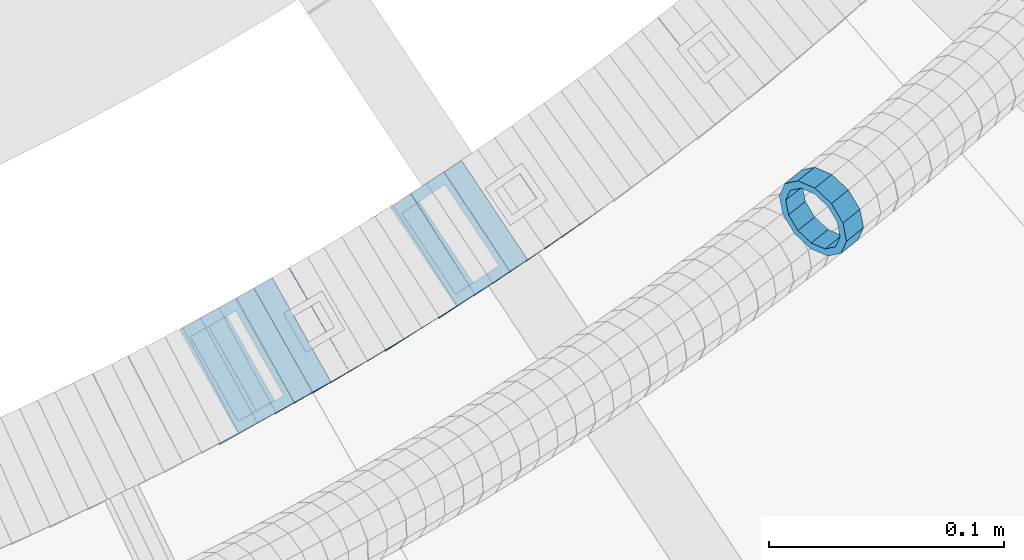
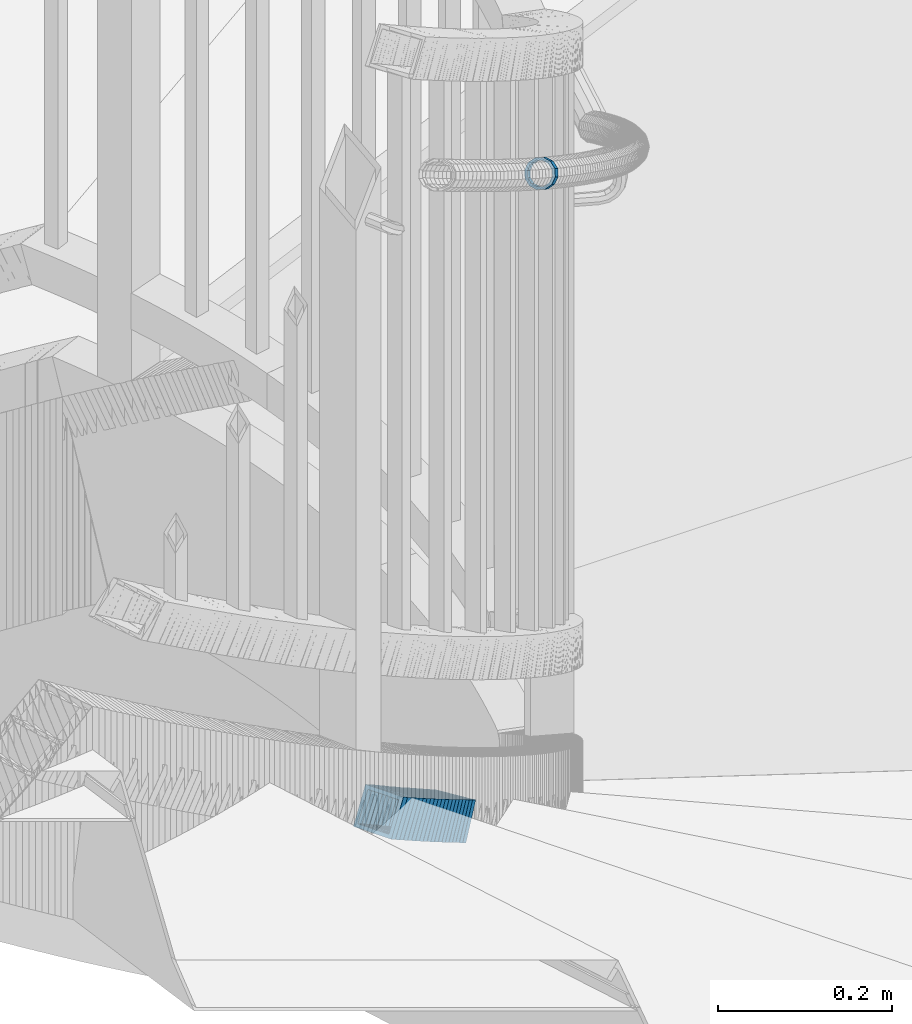
# One storey, part 736 of 975: 21 members.
"""IFC2X3 building model written with IfcOpenShell, lengths in millimetres."""

from ifc_helpers import new_model, si_unit, frame, origin_with_axes, place, context, subcontext, project, spatial, faceted_brep, material, type_object, element, save


model = new_model("IFC2X3")

# Units and contexts
model_context = context("Model", 3, precision=1e-05, world=origin_with_axes())
body_context = subcontext(model_context, "Body", "Model", "MODEL_VIEW")
ifc_project = project(units=[si_unit("LENGTHUNIT", "METRE", prefix="MILLI"), si_unit("AREAUNIT", "SQUARE_METRE"), si_unit("VOLUMEUNIT", "CUBIC_METRE"), si_unit("MASSUNIT", "GRAM", prefix="KILO"), si_unit("TIMEUNIT", "SECOND"), si_unit("PLANEANGLEUNIT", "RADIAN"), si_unit("SOLIDANGLEUNIT", "STERADIAN"), si_unit("THERMODYNAMICTEMPERATUREUNIT", "DEGREE_CELSIUS"), si_unit("LUMINOUSINTENSITYUNIT", "LUMEN")], contexts=[model_context])

# Site, building, storey
site_placement = place(None, origin_with_axes())
site = spatial("IfcSite", under=ifc_project, at=site_placement, CompositionType="ELEMENT")
building_placement = place(site_placement, origin_with_axes())
building = spatial("IfcBuilding", under=site, at=building_placement, Name="Undefined", CompositionType="ELEMENT")
storey_placement = place(building_placement, origin_with_axes())
storey = spatial("IfcBuildingStorey", under=building, at=storey_placement, Name="Undefined", CompositionType="ELEMENT", Elevation=0.0)

# Members
ifc_material = material()
member_type_1 = type_object("IfcMemberType", PredefinedType="NOTDEFINED")
member_1_placement = place(storey_placement, frame((35655.3128996887, 2245.45662166805, 3593.96255062153), z_axis=(0.627329537606273, -0.77875390929786, 3.09570168610662e-10), x_axis=(-0.659690385079403, -0.531417254063974, 0.531417254063974)))
element("IfcMember", 1, at=member_1_placement, inside=storey, type_object=member_type_1, material=ifc_material, Name="WALL", context=body_context, shape_type="Brep", body=[
    faceted_brep([(-2.1246523829177e-07, -15.367000000002, 0.0), (-1.83998054126278e-07, -13.3082123799541, 7.68350000000009), (10.9055031979988, -13.3082123799322, 7.68349999999873), (10.9055031979988, -15.3669999999729, -1.81898940354586e-12), (-1.06232619145885e-07, -7.68349999999919, 13.3082123799559), (10.9055031979842, -7.683499999981, 13.3082123799552), (-3.63797880709171e-12, 3.63797880709171e-12, 15.3670000000002), (10.9055031979697, 7.27595761418343e-12, 15.3670000000002), (1.06225343188271e-07, 7.68350000000646, 13.3082123799559), (10.9055031979478, 7.68349999999191, 13.3082123799561), (1.8399441614747e-07, 13.308212379965, 7.68350000000009), (10.9055031979333, 13.3082123799395, 7.68350000000078), (2.12461600312963e-07, 15.3670000000093, 0.0), (10.9055031979187, 15.3669999999802, 4.54747350886464e-13), (1.8399441614747e-07, 13.308212379965, -7.68350000000009), (10.9055031979187, 13.3082123799395, -7.68350000000009), (1.06225343188271e-07, 7.68350000000646, -13.3082123799559), (10.9055031979296, 7.68349999999191, -13.3082123799561), (-3.63797880709171e-12, 3.63797880709171e-12, -15.3670000000002), (10.9055031979478, 3.63797880709171e-12, -15.3670000000013), (-1.06232619145885e-07, -7.68349999999919, -13.3082123799559), (10.9055031979697, -7.683499999981, -13.3082123799575), (-1.83998054126278e-07, -13.3082123799541, -7.68350000000009), (10.9055031979842, -13.3082123799286, -7.68350000000214), (-2.63386027654633e-07, -19.0500000000029, 0.0), (-2.28097633225843e-07, -16.4977839420972, -9.52499999999964), (10.9055031979879, -16.4977839420681, -9.52500000000214), (10.9055031980097, -19.0499999999629, -2.04636307898909e-12), (-1.31691194837913e-07, -9.52500000000146, -16.4977839420935), (10.9055031979624, -9.52499999998327, -16.4977839420956), (-3.63797880709171e-12, 3.63797880709171e-12, -19.0500000000002), (10.9055031979406, 3.63797880709171e-12, -19.0500000000015), (1.31687556859106e-07, 9.52500000000509, -16.4977839420935), (10.9055031979151, 9.5249999999869, -16.4977839420942), (2.28097633225843e-07, 16.4977839421044, -9.52499999999964), (10.9055031979115, 16.4977839420717, -9.52499999999986), (2.63382389675826e-07, 19.0500000000138, 0.0), (10.9055031979115, 19.0499999999774, 6.82121026329696e-13), (2.28097633225843e-07, 16.4977839421044, 9.52499999999964), (10.9055031979296, 16.4977839420753, 9.52500000000123), (1.31687556859106e-07, 9.52500000000509, 16.4977839420935), (10.9055031979515, 9.52499999999054, 16.4977839420942), (-3.63797880709171e-12, 3.63797880709171e-12, 19.0500000000002), (10.9055031979733, 7.27595761418343e-12, 19.0500000000004), (-1.31691194837913e-07, -9.52500000000146, 16.4977839420935), (10.9055031979988, -9.52499999997599, 16.4977839420933), (-2.28097633225843e-07, -16.4977839420972, 9.52499999999964), (10.905503198006, -16.4977839420644, 9.52499999999873)], [[[0, 1, 2, 3]], [[1, 4, 5, 2]], [[4, 6, 7, 5]], [[6, 8, 9, 7]], [[8, 10, 11, 9]], [[10, 12, 13, 11]], [[12, 14, 15, 13]], [[14, 16, 17, 15]], [[16, 18, 19, 17]], [[18, 20, 21, 19]], [[20, 22, 23, 21]], [[22, 0, 3, 23]], [[24, 25, 26, 27]], [[25, 28, 29, 26]], [[28, 30, 31, 29]], [[30, 32, 33, 31]], [[32, 34, 35, 33]], [[34, 36, 37, 35]], [[36, 38, 39, 37]], [[38, 40, 41, 39]], [[40, 42, 43, 41]], [[42, 44, 45, 43]], [[44, 46, 47, 45]], [[46, 24, 27, 47]], [[29, 31, 33, 35, 37, 39, 41, 43, 45, 47, 27, 26], [5, 7, 9, 11, 13, 15, 17, 19, 21, 23, 3, 2]], [[46, 44, 42, 40, 38, 36, 34, 32, 30, 28, 25, 24], [22, 20, 18, 16, 14, 12, 10, 8, 6, 4, 1, 0]]]),
])
member_type_2 = type_object("IfcMemberType", Name="HSS2X2X.188_TUBES", PredefinedType="NOTDEFINED")
member_2_placement = place(storey_placement, frame((35403.1596586216, 2176.81287776112, 2829.18067466217), z_axis=(0.491321186669782, -0.870978467890795, 1.51524091052124e-10), x_axis=(-0.731050131101344, -0.412387253057188, 0.543601379075379)))
element("IfcMember", 2, at=member_2_placement, inside=storey, type_object=member_type_2, material=ifc_material, Name="WALL", ObjectType="HSS2X2X.188_TUBES", context=body_context, shape_type="Brep", body=[
    faceted_brep([(0.0, 20.6374999999753, -20.6375000000298), (0.0, -20.6375000000153, -20.6375000000153), (10.6709887076922, -20.6374999999844, -20.6374999999825), (10.6709887076995, 20.6375000000171, -20.6374999999753), (0.0, -20.6374999999825, 20.6375000000335), (10.6709887076922, -20.6374999999971, 20.6375000000153), (0.0, 20.6375000000116, 20.6375000000189), (10.6709887076941, 20.6375000000025, 20.6375000000189), (0.0, 25.3999999999724, -25.4000000000342), (0.0, 25.400000000016, 25.4000000000196), (10.6709887076959, 25.3999999999996, 25.4000000000233), (10.6709887077013, 25.4000000000178, -25.3999999999724), (0.0, -25.399999999976, 25.4000000000378), (10.6709887076904, -25.3999999999978, 25.400000000016), (0.0, -25.400000000016, -25.4000000000196), (10.6709887076959, -25.3999999999796, -25.3999999999796)], [[[0, 1, 2, 3]], [[1, 4, 5, 2]], [[4, 6, 7, 5]], [[6, 0, 3, 7]], [[8, 9, 10, 11]], [[9, 12, 13, 10]], [[12, 14, 15, 13]], [[14, 8, 11, 15]], [[13, 15, 11, 10], [5, 7, 3, 2]], [[14, 12, 9, 8], [6, 4, 1, 0]]]),
])
for number, where, z_axis, x_axis, name in (
    (3, (35411.1068520738, 2181.29590996488, 2823.37216906364), (0.491321186669782, -0.870978467890795, 1.51524091052124e-10), (-0.734770841274876, -0.414486115155066, 0.536947922200908), "WALL"),
    (4, (35418.9068520737, 2185.69590996487, 2817.67216906365), (0.491321186669782, -0.870978467890795, 1.51524091052124e-10), (-0.734770841274876, -0.414486115155066, 0.536947922200908), "WALL"),
):
    element("IfcMember", number, at=place(storey_placement, frame(where, z_axis=z_axis, x_axis=x_axis)), inside=storey, type_object=member_type_2, material=ifc_material, Name=name, ObjectType="HSS2X2X.188_TUBES", context=body_context, shape_type="Brep", body=[
        faceted_brep([(0.0, 20.6374999999753, -20.6375000000298), (0.0, -20.6375000000153, -20.6375000000153), (10.6216759506497, -20.637499999968, -20.6374999999534), (10.6216759506497, 20.6375000000262, -20.6374999999643), (0.0, -20.6374999999825, 20.6375000000335), (10.6216759506169, -20.6374999999935, 20.637500000008), (0.0, 20.6375000000116, 20.6375000000189), (10.6216759506242, 20.6375000000007, 20.6374999999971), (0.0, 25.3999999999724, -25.4000000000342), (0.0, 25.400000000016, 25.4000000000196), (10.6216759506169, 25.3999999999978, 25.3999999999869), (10.6216759506533, 25.4000000000269, -25.3999999999614), (0.0, -25.399999999976, 25.4000000000378), (10.6216759506242, -25.3999999999942, 25.4000000000051), (0.0, -25.400000000016, -25.4000000000196), (10.6216759506569, -25.3999999999614, -25.3999999999432)], [[[0, 1, 2, 3]], [[1, 4, 5, 2]], [[4, 6, 7, 5]], [[6, 0, 3, 7]], [[8, 9, 10, 11]], [[9, 12, 13, 10]], [[12, 14, 15, 13]], [[14, 8, 11, 15]], [[13, 15, 11, 10], [5, 7, 3, 2]], [[14, 12, 9, 8], [6, 4, 1, 0]]]),
    ])
member_3_placement = place(storey_placement, frame((35426.4589226349, 2189.90195285872, 2811.94601811882), z_axis=(0.499722453606395, -0.866185585981205, -3.44356067216722e-10), x_axis=(-0.728209106903342, -0.420120638944253, 0.541488822928147)))
element("IfcMember", 5, at=member_3_placement, inside=storey, type_object=member_type_2, material=ifc_material, Name="WALL", ObjectType="HSS2X2X.188_TUBES", context=body_context, shape_type="Brep", body=[
    faceted_brep([(0.0, 20.6374999999753, -20.6375000000298), (0.0, -20.6375000000153, -20.6375000000153), (10.7093417165161, -20.637499999968, -20.6374999999534), (10.709341716436, 20.6374999999898, -20.6375000000116), (0.0, -20.6374999999825, 20.6375000000335), (10.7093417164688, -20.6374999999971, 20.6375000000153), (0.0, 20.6375000000116, 20.6375000000189), (10.7093417163924, 20.6374999999643, 20.6374999999571), (0.0, 25.3999999999724, -25.4000000000342), (0.0, 25.400000000016, 25.4000000000196), (10.7093417163815, 25.3999999999542, 25.3999999999469), (10.7093417164288, 25.3999999999869, -25.4000000000196), (0.0, -25.399999999976, 25.4000000000378), (10.7093417164724, -25.3999999999942, 25.4000000000196), (0.0, -25.400000000016, -25.4000000000196), (10.709341716527, -25.3999999999578, -25.3999999999432)], [[[0, 1, 2, 3]], [[1, 4, 5, 2]], [[4, 6, 7, 5]], [[6, 0, 3, 7]], [[8, 9, 10, 11]], [[9, 12, 13, 10]], [[12, 14, 15, 13]], [[14, 8, 11, 15]], [[13, 15, 11, 10], [5, 7, 3, 2]], [[14, 12, 9, 8], [6, 4, 1, 0]]]),
])
member_4_placement = place(storey_placement, frame((35434.1394897285, 2194.30179687593, 2806.19775448158), z_axis=(0.504568019426507, -0.863371944049615, -2.19346475205384e-10), x_axis=(-0.727484185892216, -0.425153095937027, 0.538527254920214)))
element("IfcMember", 6, at=member_4_placement, inside=storey, type_object=member_type_2, material=ifc_material, Name="WALL", ObjectType="HSS2X2X.188_TUBES", context=body_context, shape_type="Brep", body=[
    faceted_brep([(0.0, 20.6374999999753, -20.6375000000298), (0.0, -20.6375000000153, -20.6375000000153), (10.5806427026419, -20.6374999999607, -20.6374999999316), (10.5806427026473, 20.6375000000444, -20.6374999999207), (0.0, -20.6374999999825, 20.6375000000335), (10.5806427025509, -20.6375000000207, 20.6374999999643), (0.0, 20.6375000000116, 20.6375000000189), (10.5806427025545, 20.6374999999862, 20.6374999999716), (0.0, 25.3999999999724, -25.4000000000342), (0.0, 25.400000000016, 25.4000000000196), (10.5806427025436, 25.3999999999796, 25.3999999999614), (10.5806427026582, 25.4000000000542, -25.3999999999105), (0.0, -25.399999999976, 25.4000000000378), (10.5806427025418, -25.4000000000287, 25.3999999999542), (0.0, -25.400000000016, -25.4000000000196), (10.5806427026528, -25.3999999999542, -25.3999999999178)], [[[0, 1, 2, 3]], [[1, 4, 5, 2]], [[4, 6, 7, 5]], [[6, 0, 3, 7]], [[8, 9, 10, 11]], [[9, 12, 13, 10]], [[12, 14, 15, 13]], [[14, 8, 11, 15]], [[13, 15, 11, 10], [5, 7, 3, 2]], [[14, 12, 9, 8], [6, 4, 1, 0]]]),
])
member_5_placement = place(storey_placement, frame((35441.598327349, 2198.60572369306, 2800.47087936196), z_axis=(0.51285525212439, -0.858475095951204, -8.52323864819481e-11), x_axis=(-0.720886570579887, -0.43065950974905, 0.543005468683582)))
element("IfcMember", 7, at=member_5_placement, inside=storey, type_object=member_type_2, material=ifc_material, Name="WALL", ObjectType="HSS2X2X.188_TUBES", context=body_context, shape_type="Brep", body=[
    faceted_brep([(0.0, 20.6374999999753, -20.6375000000298), (0.0, -20.6375000000153, -20.6375000000153), (10.6831643251735, -20.6375000000498, -20.6375000000953), (10.6831643252044, 20.637499999988, -20.6375000000226), (0.0, -20.6374999999825, 20.6375000000335), (10.6831643251935, -20.6375000000135, 20.637499999968), (0.0, 20.6375000000116, 20.6375000000189), (10.6831643252244, 20.6375000000226, 20.6375000000407), (0.0, 25.3999999999724, -25.4000000000342), (0.0, 25.400000000016, 25.4000000000196), (10.6831643252317, 25.4000000000306, 25.4000000000597), (10.6831643252044, 25.3999999999905, -25.4000000000196), (0.0, -25.399999999976, 25.4000000000378), (10.6831643251917, -25.400000000016, 25.3999999999614), (0.0, -25.400000000016, -25.4000000000196), (10.6831643251644, -25.400000000056, -25.4000000001179)], [[[0, 1, 2, 3]], [[1, 4, 5, 2]], [[4, 6, 7, 5]], [[6, 0, 3, 7]], [[8, 9, 10, 11]], [[9, 12, 13, 10]], [[12, 14, 15, 13]], [[14, 8, 11, 15]], [[13, 15, 11, 10], [5, 7, 3, 2]], [[14, 12, 9, 8], [6, 4, 1, 0]]]),
])
member_6_placement = place(storey_placement, frame((35449.1784894769, 2203.1011392955, 2794.72209377705), z_axis=(0.517802678981105, -0.855500079275268, 1.01825207821094e-10), x_axis=(-0.720031514804977, -0.435808547881956, 0.540023635853721)))
element("IfcMember", 8, at=member_6_placement, inside=storey, type_object=member_type_2, material=ifc_material, Name="WALL", ObjectType="HSS2X2X.188_TUBES", context=body_context, shape_type="Brep", body=[
    faceted_brep([(0.0, 20.6374999999753, -20.6375000000298), (0.0, -20.6375000000153, -20.6375000000153), (10.5550935571373, -20.6374999999935, -20.6374999999753), (10.5550935571373, 20.6375000000025, -20.6374999999862), (0.0, -20.6374999999825, 20.6375000000335), (10.5550935571027, -20.6374999999989, 20.6374999999862), (0.0, 20.6375000000116, 20.6375000000189), (10.5550935571027, 20.6374999999953, 20.6374999999716), (0.0, 25.3999999999724, -25.4000000000342), (0.0, 25.400000000016, 25.4000000000196), (10.5550935570991, 25.3999999999924, 25.3999999999651), (10.5550935571373, 25.3999999999996, -25.3999999999905), (0.0, -25.399999999976, 25.4000000000378), (10.5550935571009, -25.3999999999996, 25.3999999999833), (0.0, -25.400000000016, -25.4000000000196), (10.5550935571428, -25.3999999999905, -25.3999999999724)], [[[0, 1, 2, 3]], [[1, 4, 5, 2]], [[4, 6, 7, 5]], [[6, 0, 3, 7]], [[8, 9, 10, 11]], [[9, 12, 13, 10]], [[12, 14, 15, 13]], [[14, 8, 11, 15]], [[13, 15, 11, 10], [5, 7, 3, 2]], [[14, 12, 9, 8], [6, 4, 1, 0]]]),
])
member_7_placement = place(storey_placement, frame((35456.8069512311, 2207.69752496903, 2788.9348533772), z_axis=(0.521001549994652, -0.853555730402632, -1.97164808923844e-10), x_axis=(-0.717966273129313, -0.438239154078941, 0.540805764097407)))
element("IfcMember", 9, at=member_7_placement, inside=storey, type_object=member_type_2, material=ifc_material, Name="WALL", ObjectType="HSS2X2X.188_TUBES", context=body_context, shape_type="Brep", body=[
    faceted_brep([(0.0, 20.6374999999753, -20.6375000000298), (0.0, -20.6375000000153, -20.6375000000153), (10.7247377590011, -20.6375000000189, -20.6375000000589), (10.7247377589938, 20.6374999999844, -20.6375000000698), (0.0, -20.6374999999825, 20.6375000000335), (10.7247377590484, -20.6374999999771, 20.6375000000517), (0.0, 20.6375000000116, 20.6375000000189), (10.7247377590447, 20.6375000000262, 20.6375000000407), (0.0, 25.3999999999724, -25.4000000000342), (0.0, 25.400000000016, 25.4000000000196), (10.7247377590484, 25.4000000000342, 25.400000000056), (10.7247377589902, 25.3999999999778, -25.4000000000851), (0.0, -25.399999999976, 25.4000000000378), (10.7247377590556, -25.3999999999724, 25.4000000000633), (0.0, -25.400000000016, -25.4000000000196), (10.7247377589938, -25.4000000000251, -25.4000000000742)], [[[0, 1, 2, 3]], [[1, 4, 5, 2]], [[4, 6, 7, 5]], [[6, 0, 3, 7]], [[8, 9, 10, 11]], [[9, 12, 13, 10]], [[12, 14, 15, 13]], [[14, 8, 11, 15]], [[13, 15, 11, 10], [5, 7, 3, 2]], [[14, 12, 9, 8], [6, 4, 1, 0]]]),
])
member_8_placement = place(storey_placement, frame((35464.3879811797, 2212.29213373258, 2783.18569583919), z_axis=(0.525969302181787, -0.850503552704164, -1.9787603378063e-10), x_axis=(-0.71704495166101, -0.443435693790348, 0.537783713745715)))
element("IfcMember", 10, at=member_8_placement, inside=storey, type_object=member_type_2, material=ifc_material, Name="WALL", ObjectType="HSS2X2X.188_TUBES", context=body_context, shape_type="Brep", body=[
    faceted_brep([(0.0, 20.6374999999753, -20.6375000000298), (0.0, -20.6375000000153, -20.6375000000153), (10.6004716875832, -20.6375000000153, -20.6375000000553), (10.6004716875814, 20.6374999999898, -20.6375000000444), (0.0, -20.6374999999825, 20.6375000000335), (10.6004716876068, -20.6375000000044, 20.6374999999862), (0.0, 20.6375000000116, 20.6375000000189), (10.6004716876032, 20.6374999999989, 20.6374999999971), (0.0, 25.3999999999724, -25.4000000000342), (0.0, 25.400000000016, 25.4000000000196), (10.600471687605, 25.4000000000015, 25.4000000000051), (10.6004716875814, 25.3999999999869, -25.4000000000487), (0.0, -25.399999999976, 25.4000000000378), (10.6004716876068, -25.4000000000015, 25.3999999999905), (0.0, -25.400000000016, -25.4000000000196), (10.6004716875814, -25.4000000000178, -25.4000000000669)], [[[0, 1, 2, 3]], [[1, 4, 5, 2]], [[4, 6, 7, 5]], [[6, 0, 3, 7]], [[8, 9, 10, 11]], [[9, 12, 13, 10]], [[12, 14, 15, 13]], [[14, 8, 11, 15]], [[13, 15, 11, 10], [5, 7, 3, 2]], [[14, 12, 9, 8], [6, 4, 1, 0]]]),
])
member_9_placement = place(storey_placement, frame((35471.6393027925, 2216.68588661606, 2777.50753289956), z_axis=(0.539053696363117, -0.842271400700072, -2.99270595860435e-10), x_axis=(-0.709380442229691, -0.454003483147033, 0.5391291361746)))
element("IfcMember", 11, at=member_9_placement, inside=storey, type_object=member_type_2, material=ifc_material, Name="WALL", ObjectType="HSS2X2X.188_TUBES", context=body_context, shape_type="Brep", body=[
    faceted_brep([(0.0, 20.6374999999753, -20.6375000000298), (0.0, -20.6375000000153, -20.6375000000153), (10.5744976239494, -20.6375000000207, -20.6375000000335), (10.5744976239657, 20.6375000000098, -20.637500000008), (0.0, -20.6374999999825, 20.6375000000335), (10.5744976239639, -20.6375000000244, 20.6374999999753), (0.0, 20.6375000000116, 20.6375000000189), (10.5744976239803, 20.6374999999989, 20.6374999999935), (0.0, 25.3999999999724, -25.4000000000342), (0.0, 25.400000000016, 25.4000000000196), (10.5744976239857, 25.4000000000051, 25.4000000000015), (10.5744976239675, 25.4000000000124, -25.4000000000051), (0.0, -25.399999999976, 25.4000000000378), (10.5744976239639, -25.4000000000287, 25.3999999999724), (0.0, -25.400000000016, -25.4000000000196), (10.5744976239494, -25.4000000000215, -25.4000000000378)], [[[0, 1, 2, 3]], [[1, 4, 5, 2]], [[4, 6, 7, 5]], [[6, 0, 3, 7]], [[8, 9, 10, 11]], [[9, 12, 13, 10]], [[12, 14, 15, 13]], [[14, 8, 11, 15]], [[13, 15, 11, 10], [5, 7, 3, 2]], [[14, 12, 9, 8], [6, 4, 1, 0]]]),
])
member_10_placement = place(storey_placement, frame((35479.2583846463, 2221.59560662445, 2771.75724533005), z_axis=(0.533992991595071, -0.845488902900178, -3.59032583219232e-10), x_axis=(-0.710435520923845, -0.448696118951872, 0.542174476941872)))
element("IfcMember", 12, at=member_10_placement, inside=storey, type_object=member_type_2, material=ifc_material, Name="WALL", ObjectType="HSS2X2X.188_TUBES", context=body_context, shape_type="Brep", body=[
    faceted_brep([(0.0, 20.6374999999753, -20.6375000000298), (0.0, -20.6375000000153, -20.6375000000153), (10.6985980389491, -20.6375000000317, -20.6375000000698), (10.6985980389982, 20.6375000000116, -20.6374999999643), (0.0, -20.6374999999825, 20.6375000000335), (10.6985980389818, -20.6374999999989, 20.6374999999789), (0.0, 20.6375000000116, 20.6375000000189), (10.6985980390309, 20.6375000000407, 20.6375000000808), (0.0, 25.3999999999724, -25.4000000000342), (0.0, 25.400000000016, 25.4000000000196), (10.6985980390382, 25.4000000000487, 25.4000000000997), (10.6985980390036, 25.4000000000142, -25.3999999999542), (0.0, -25.399999999976, 25.4000000000378), (10.6985980389763, -25.4000000000033, 25.3999999999724), (0.0, -25.400000000016, -25.4000000000196), (10.6985980389418, -25.400000000036, -25.4000000000851)], [[[0, 1, 2, 3]], [[1, 4, 5, 2]], [[4, 6, 7, 5]], [[6, 0, 3, 7]], [[8, 9, 10, 11]], [[9, 12, 13, 10]], [[12, 14, 15, 13]], [[14, 8, 11, 15]], [[13, 15, 11, 10], [5, 7, 3, 2]], [[14, 12, 9, 8], [6, 4, 1, 0]]]),
])
member_11_placement = place(storey_placement, frame((35486.7393027925, 2226.28588661606, 2766.00753289956), z_axis=(0.539053696363117, -0.842271400700072, -2.99270595860435e-10), x_axis=(-0.709380442229691, -0.454003483147033, 0.5391291361746)))
element("IfcMember", 13, at=member_11_placement, inside=storey, type_object=member_type_2, material=ifc_material, Name="WALL", ObjectType="HSS2X2X.188_TUBES", context=body_context, shape_type="Brep", body=[
    faceted_brep([(0.0, 20.6374999999753, -20.6375000000298), (0.0, -20.6375000000153, -20.6375000000153), (10.5744976239494, -20.6375000000207, -20.6375000000335), (10.5744976239657, 20.6375000000098, -20.637500000008), (0.0, -20.6374999999825, 20.6375000000335), (10.5744976239639, -20.6375000000244, 20.6374999999753), (0.0, 20.6375000000116, 20.6375000000189), (10.5744976239803, 20.6374999999989, 20.6374999999935), (0.0, 25.3999999999724, -25.4000000000342), (0.0, 25.400000000016, 25.4000000000196), (10.5744976239857, 25.4000000000051, 25.4000000000015), (10.5744976239675, 25.4000000000124, -25.4000000000051), (0.0, -25.399999999976, 25.4000000000378), (10.5744976239639, -25.4000000000287, 25.3999999999724), (0.0, -25.400000000016, -25.4000000000196), (10.5744976239494, -25.4000000000215, -25.4000000000378)], [[[0, 1, 2, 3]], [[1, 4, 5, 2]], [[4, 6, 7, 5]], [[6, 0, 3, 7]], [[8, 9, 10, 11]], [[9, 12, 13, 10]], [[12, 14, 15, 13]], [[14, 8, 11, 15]], [[13, 15, 11, 10], [5, 7, 3, 2]], [[14, 12, 9, 8], [6, 4, 1, 0]]]),
])
member_12_placement = place(storey_placement, frame((35493.8976285115, 2230.77393133963, 2760.328027268), z_axis=(0.552097343096909, -0.833779661388627, 8.59072315506636e-11), x_axis=(-0.701555755945148, -0.464543675963691, 0.540387540957759)))
element("IfcMember", 14, at=member_12_placement, inside=storey, type_object=member_type_2, material=ifc_material, Name="WALL", ObjectType="HSS2X2X.188_TUBES", context=body_context, shape_type="Brep", body=[
    faceted_brep([(0.0, 20.6374999999753, -20.6375000000298), (0.0, -20.6375000000153, -20.6375000000153), (10.5531985672587, -20.6374999999916, -20.6375000000007), (10.5531985672878, 20.6375000000062, -20.6374999999789), (0.0, -20.6374999999825, 20.6375000000335), (10.5531985672114, -20.6375000000353, 20.6374999999171), (0.0, 20.6375000000116, 20.6375000000189), (10.5531985672333, 20.6374999999607, 20.6374999999316), (0.0, 25.3999999999724, -25.4000000000342), (0.0, 25.400000000016, 25.4000000000196), (10.5531985672314, 25.399999999956, 25.3999999999251), (10.5531985672933, 25.4000000000106, -25.3999999999724), (0.0, -25.399999999976, 25.4000000000378), (10.5531985672023, -25.4000000000397, 25.3999999999069), (0.0, -25.400000000016, -25.4000000000196), (10.5531985672642, -25.3999999999851, -25.3999999999869)], [[[0, 1, 2, 3]], [[1, 4, 5, 2]], [[4, 6, 7, 5]], [[6, 0, 3, 7]], [[8, 9, 10, 11]], [[9, 12, 13, 10]], [[12, 14, 15, 13]], [[14, 8, 11, 15]], [[13, 15, 11, 10], [5, 7, 3, 2]], [[14, 12, 9, 8], [6, 4, 1, 0]]]),
])
member_13_placement = place(storey_placement, frame((35501.480447215, 2235.77774183277, 2754.53213827413), z_axis=(0.554700196030179, -0.832050294467877, 1.48236722452566e-10), x_axis=(-0.703241758862587, -0.468827838908382, 0.534463736895546)))
element("IfcMember", 15, at=member_13_placement, inside=storey, type_object=member_type_2, material=ifc_material, Name="WALL", ObjectType="HSS2X2X.188_TUBES", context=body_context, shape_type="Brep", body=[
    faceted_brep([(0.0, 20.6374999999753, -20.6375000000298), (0.0, -20.6375000000153, -20.6375000000153), (10.6625512894789, -20.6374999999625, -20.6374999999389), (10.6625512893879, 20.6374999999789, -20.6375000000371), (0.0, -20.6374999999825, 20.6375000000335), (10.6625512894352, -20.6374999999989, 20.6375000000153), (0.0, 20.6375000000116, 20.6375000000189), (10.6625512893443, 20.6374999999443, 20.6374999999134), (0.0, 25.3999999999724, -25.4000000000342), (0.0, 25.400000000016, 25.4000000000196), (10.6625512893297, 25.3999999999342, 25.3999999998996), (10.6625512893916, 25.399999999976, -25.4000000000415), (0.0, -25.399999999976, 25.4000000000378), (10.6625512894389, -25.399999999996, 25.400000000016), (0.0, -25.400000000016, -25.4000000000196), (10.6625512894971, -25.3999999999523, -25.3999999999214)], [[[0, 1, 2, 3]], [[1, 4, 5, 2]], [[4, 6, 7, 5]], [[6, 0, 3, 7]], [[8, 9, 10, 11]], [[9, 12, 13, 10]], [[12, 14, 15, 13]], [[14, 8, 11, 15]], [[13, 15, 11, 10], [5, 7, 3, 2]], [[14, 12, 9, 8], [6, 4, 1, 0]]]),
])
member_14_placement = place(storey_placement, frame((35508.5819565581, 2240.47488990358, 2748.89803033737), z_axis=(0.559857411630225, -0.828588968453421, -5.37864252692088e-10), x_axis=(-0.694904609116096, -0.469530142078484, 0.544654964090997)))
element("IfcMember", 16, at=member_14_placement, inside=storey, type_object=member_type_2, material=ifc_material, Name="WALL", ObjectType="HSS2X2X.188_TUBES", context=body_context, shape_type="Brep", body=[
    faceted_brep([(0.0, 20.6374999999753, -20.6375000000298), (0.0, -20.6375000000153, -20.6375000000153), (10.648004507897, -20.6374999999862, -20.637499999968), (10.6480045078188, 20.6374999999771, -20.6375000000808), (0.0, -20.6374999999825, 20.6375000000335), (10.6480045079406, -20.6374999999698, 20.6375000001062), (0.0, 20.6375000000116, 20.6375000000189), (10.6480045078679, 20.6374999999935, 20.6375000000007), (0.0, 25.3999999999724, -25.4000000000342), (0.0, 25.400000000016, 25.4000000000196), (10.6480045078661, 25.3999999999905, 25.4000000000015), (10.648004507806, 25.3999999999705, -25.4000000000997), (0.0, -25.399999999976, 25.4000000000378), (10.6480045079552, -25.3999999999633, 25.4000000001288), (0.0, -25.400000000016, -25.4000000000196), (10.6480045078988, -25.3999999999814, -25.3999999999651)], [[[0, 1, 2, 3]], [[1, 4, 5, 2]], [[4, 6, 7, 5]], [[6, 0, 3, 7]], [[8, 9, 10, 11]], [[9, 12, 13, 10]], [[12, 14, 15, 13]], [[14, 8, 11, 15]], [[13, 15, 11, 10], [5, 7, 3, 2]], [[14, 12, 9, 8], [6, 4, 1, 0]]]),
])
member_15_placement = place(storey_placement, frame((35515.863230544, 2245.35658153436, 2743.14713360921), z_axis=(0.565089006166999, -0.825029948007461, -8.60381987877188e-11), x_axis=(-0.693573002028166, -0.475050002019327, 0.541557002022017)))
element("IfcMember", 17, at=member_15_placement, inside=storey, type_object=member_type_2, material=ifc_material, Name="WALL", ObjectType="HSS2X2X.188_TUBES", context=body_context, shape_type="Brep", body=[
    faceted_brep([(0.0, 20.6374999999753, -20.6375000000298), (0.0, -20.6375000000153, -20.6375000000153), (10.5290075505945, -20.637499999968, -20.6375000000116), (10.5290075505436, 20.6374999999898, -20.637499999998), (0.0, -20.6374999999825, 20.6375000000335), (10.5290075505145, -20.6375000000189, 20.637500000008), (0.0, 20.6375000000116, 20.6375000000189), (10.5290075504672, 20.6374999999462, 20.6375000000198), (0.0, 25.3999999999724, -25.4000000000342), (0.0, 25.400000000016, 25.4000000000196), (10.5290075504563, 25.399999999936, 25.4000000000224), (10.5290075505472, 25.3999999999869, -25.3999999999987), (0.0, -25.399999999976, 25.4000000000378), (10.5290075505072, -25.4000000000196, 25.4000000000106), (0.0, -25.400000000016, -25.4000000000196), (10.5290075506091, -25.3999999999651, -25.4000000000151)], [[[0, 1, 2, 3]], [[1, 4, 5, 2]], [[4, 6, 7, 5]], [[6, 0, 3, 7]], [[8, 9, 10, 11]], [[9, 12, 13, 10]], [[12, 14, 15, 13]], [[14, 8, 11, 15]], [[13, 15, 11, 10], [5, 7, 3, 2]], [[14, 12, 9, 8], [6, 4, 1, 0]]]),
])
member_16_placement = place(storey_placement, frame((35523.3498979407, 2250.46812147387, 2737.35033670451), z_axis=(0.567472910754157, -0.823392066733828, 3.25858309224714e-11), x_axis=(-0.695333960268593, -0.479216648185092, 0.535595078206887)))
element("IfcMember", 18, at=member_16_placement, inside=storey, type_object=member_type_2, material=ifc_material, Name="WALL", ObjectType="HSS2X2X.188_TUBES", context=body_context, shape_type="Brep", body=[
    faceted_brep([(0.0, 20.6374999999753, -20.6375000000298), (0.0, -20.6375000000153, -20.6375000000153), (10.6395488625676, -20.6374999999771, -20.6374999999716), (10.6395488625531, 20.6374999999916, -20.6375000000189), (0.0, -20.6374999999825, 20.6375000000335), (10.6395488625731, -20.6374999999844, 20.6375000000153), (0.0, 20.6375000000116, 20.6375000000189), (10.6395488625585, 20.6374999999825, 20.637499999968), (0.0, 25.3999999999724, -25.4000000000342), (0.0, 25.400000000016, 25.4000000000196), (10.6395488625567, 25.3999999999778, 25.3999999999614), (10.6395488625494, 25.3999999999887, -25.4000000000233), (0.0, -25.399999999976, 25.4000000000378), (10.6395488625749, -25.3999999999851, 25.400000000016), (0.0, -25.400000000016, -25.4000000000196), (10.6395488625658, -25.399999999976, -25.3999999999687)], [[[0, 1, 2, 3]], [[1, 4, 5, 2]], [[4, 6, 7, 5]], [[6, 0, 3, 7]], [[8, 9, 10, 11]], [[9, 12, 13, 10]], [[12, 14, 15, 13]], [[14, 8, 11, 15]], [[13, 15, 11, 10], [5, 7, 3, 2]], [[14, 12, 9, 8], [6, 4, 1, 0]]]),
])
member_17_placement = place(storey_placement, frame((35530.354622704, 2255.25670945389, 2731.71633481282), z_axis=(0.572708439164023, -0.819759137619282, -2.29586476052645e-10), x_axis=(-0.686908622877599, -0.479895065914522, 0.54576301590278)))
element("IfcMember", 19, at=member_17_placement, inside=storey, type_object=member_type_2, material=ifc_material, Name="WALL", ObjectType="HSS2X2X.188_TUBES", context=body_context, shape_type="Brep", body=[
    faceted_brep([(0.0, 20.6374999999753, -20.6375000000298), (0.0, -20.6375000000153, -20.6375000000153), (10.6348483769107, -20.637499999988, -20.6374999999825), (10.6348483768415, 20.6374999999734, -20.6375000001026), (0.0, -20.6374999999825, 20.6375000000335), (10.6348483769852, -20.6374999999589, 20.6375000001462), (0.0, 20.6375000000116, 20.6375000000189), (10.6348483769161, 20.6375000000044, 20.6375000000226), (0.0, 25.3999999999724, -25.4000000000342), (0.0, 25.400000000016, 25.4000000000196), (10.6348483769179, 25.4000000000015, 25.4000000000233), (10.6348483768288, 25.3999999999669, -25.4000000001324), (0.0, -25.399999999976, 25.4000000000378), (10.6348483769998, -25.3999999999505, 25.4000000001688), (0.0, -25.400000000016, -25.4000000000196), (10.6348483769107, -25.3999999999887, -25.3999999999833)], [[[0, 1, 2, 3]], [[1, 4, 5, 2]], [[4, 6, 7, 5]], [[6, 0, 3, 7]], [[8, 9, 10, 11]], [[9, 12, 13, 10]], [[12, 14, 15, 13]], [[14, 8, 11, 15]], [[13, 15, 11, 10], [5, 7, 3, 2]], [[14, 12, 9, 8], [6, 4, 1, 0]]]),
])
member_18_placement = place(storey_placement, frame((35537.7266443286, 2260.35364829386, 2725.86716837123), z_axis=(0.580182279890535, -0.814486661708478, -5.08648554387038e-11), x_axis=(-0.687273838311968, -0.489564926222173, 0.536638476243563)))
element("IfcMember", 20, at=member_18_placement, inside=storey, type_object=member_type_2, material=ifc_material, Name="WALL", ObjectType="HSS2X2X.188_TUBES", context=body_context, shape_type="Brep", body=[
    faceted_brep([(0.0, 20.6374999999753, -20.6375000000298), (0.0, -20.6375000000153, -20.6375000000153), (10.6216759506497, -20.637499999968, -20.6374999999534), (10.6216759506497, 20.6375000000262, -20.6374999999643), (0.0, -20.6374999999825, 20.6375000000335), (10.6216759506169, -20.6374999999935, 20.637500000008), (0.0, 20.6375000000116, 20.6375000000189), (10.6216759506242, 20.6375000000007, 20.6374999999971), (0.0, 25.3999999999724, -25.4000000000342), (0.0, 25.400000000016, 25.4000000000196), (10.6216759506169, 25.3999999999978, 25.3999999999869), (10.6216759506533, 25.4000000000269, -25.3999999999614), (0.0, -25.399999999976, 25.4000000000378), (10.6216759506242, -25.3999999999942, 25.4000000000051), (0.0, -25.400000000016, -25.4000000000196), (10.6216759506569, -25.3999999999614, -25.3999999999432)], [[[0, 1, 2, 3]], [[1, 4, 5, 2]], [[4, 6, 7, 5]], [[6, 0, 3, 7]], [[8, 9, 10, 11]], [[9, 12, 13, 10]], [[12, 14, 15, 13]], [[14, 8, 11, 15]], [[13, 15, 11, 10], [5, 7, 3, 2]], [[14, 12, 9, 8], [6, 4, 1, 0]]]),
])
member_19_placement = place(storey_placement, frame((35544.7720104363, 2265.33280008808, 2720.22367431757), z_axis=(0.58549055389883, -0.81067922836054, 1.88117155630607e-10), x_axis=(-0.682257607152531, -0.492741605110134, 0.540120605120738)))
element("IfcMember", 21, at=member_19_placement, inside=storey, type_object=member_type_2, material=ifc_material, Name="WALL", ObjectType="HSS2X2X.188_TUBES", context=body_context, shape_type="Brep", body=[
    faceted_brep([(0.0, 20.6374999999753, -20.6375000000298), (0.0, -20.6375000000153, -20.6375000000153), (10.5531985672587, -20.6374999999916, -20.6375000000007), (10.5531985672878, 20.6375000000062, -20.6374999999789), (0.0, -20.6374999999825, 20.6375000000335), (10.5531985672114, -20.6375000000353, 20.6374999999171), (0.0, 20.6375000000116, 20.6375000000189), (10.5531985672333, 20.6374999999607, 20.6374999999316), (0.0, 25.3999999999724, -25.4000000000342), (0.0, 25.400000000016, 25.4000000000196), (10.5531985672314, 25.399999999956, 25.3999999999251), (10.5531985672933, 25.4000000000106, -25.3999999999724), (0.0, -25.399999999976, 25.4000000000378), (10.5531985672023, -25.4000000000397, 25.3999999999069), (0.0, -25.400000000016, -25.4000000000196), (10.5531985672642, -25.3999999999851, -25.3999999999869)], [[[0, 1, 2, 3]], [[1, 4, 5, 2]], [[4, 6, 7, 5]], [[6, 0, 3, 7]], [[8, 9, 10, 11]], [[9, 12, 13, 10]], [[12, 14, 15, 13]], [[14, 8, 11, 15]], [[13, 15, 11, 10], [5, 7, 3, 2]], [[14, 12, 9, 8], [6, 4, 1, 0]]]),
])

save(model, "model.ifc")
